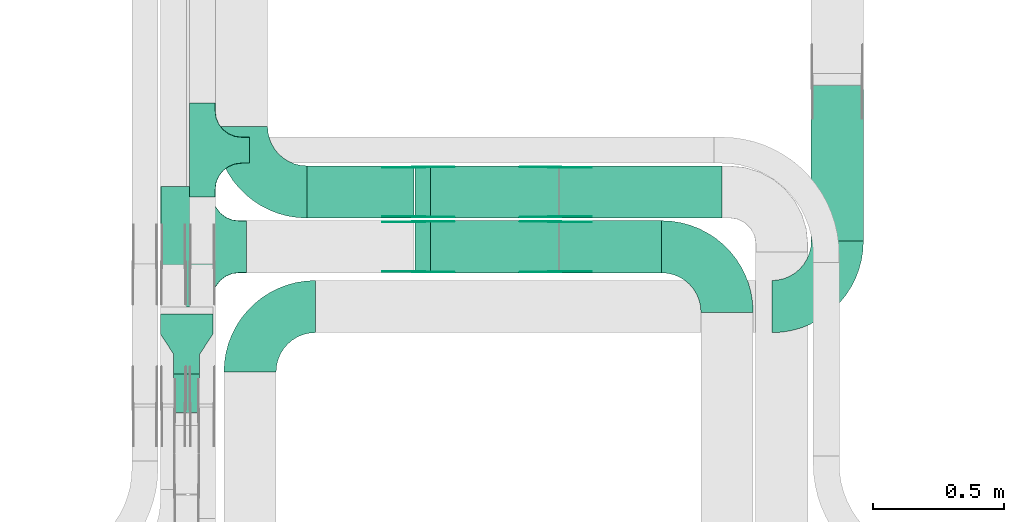
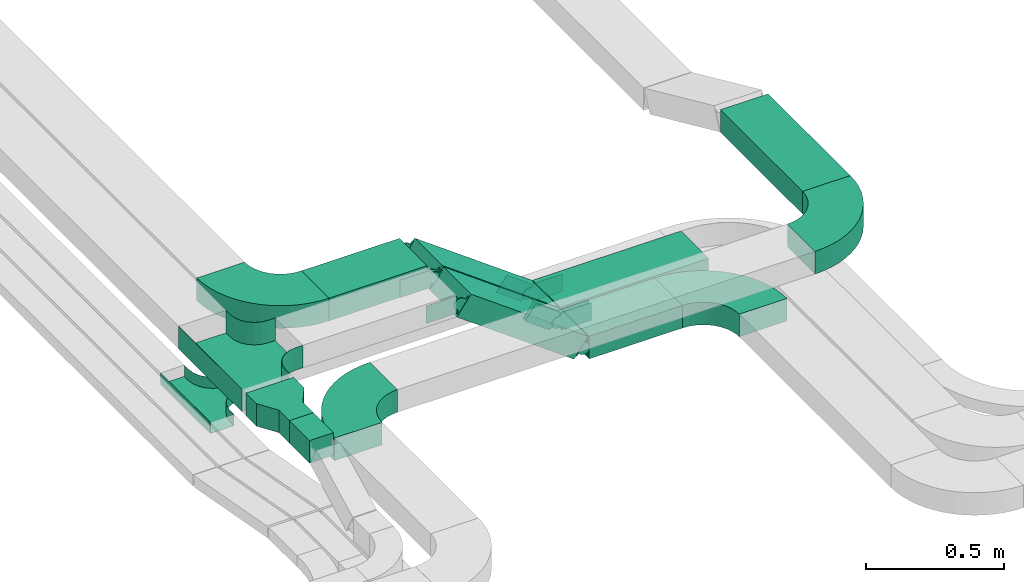
# One storey, part 11 of 25: 23 flow fittings, 7 flow segments.
"""IFC2X3 building model written with IfcOpenShell, lengths in millimetres."""

from ifc_helpers import new_model, entity, si_unit, converted_unit, derived_unit, direction, frame, frame_2d, origin, origin_2d_with_axis, place, context, subcontext, project, spatial, polyline, circle_curve, parameter, trimmed, segment, composite_curve, rectangle, outline, extrude, faceted_brep, source, transform, mapped, material, type_object, type_shapes, element, save


model = new_model("IFC2X3")

# Units and contexts
model_context = context("Model", 3, precision=0.01, world=origin(), true_north=direction((6.12303176911189e-17, 1.0)))
body_context = subcontext(model_context, "Body", "Model", "MODEL_VIEW")
ifc_project = project(units=[si_unit("LENGTHUNIT", "METRE", prefix="MILLI"), si_unit("AREAUNIT", "SQUARE_METRE"), si_unit("VOLUMEUNIT", "CUBIC_METRE"), converted_unit("PLANEANGLEUNIT", "DEGREE", entity("IfcRatioMeasure", 0.0174532925199433), si_unit("PLANEANGLEUNIT", "RADIAN"), dimensions=[0, 0, 0, 0, 0, 0, 0]), si_unit("MASSUNIT", "GRAM", prefix="KILO"), derived_unit("MASSDENSITYUNIT", [(si_unit("MASSUNIT", "GRAM", prefix="KILO"), 1), (si_unit("LENGTHUNIT", "METRE"), -3)]), derived_unit("MOMENTOFINERTIAUNIT", [(si_unit("LENGTHUNIT", "METRE"), 4)]), si_unit("TIMEUNIT", "SECOND"), si_unit("FREQUENCYUNIT", "HERTZ"), si_unit("THERMODYNAMICTEMPERATUREUNIT", "DEGREE_CELSIUS"), derived_unit("THERMALTRANSMITTANCEUNIT", [(si_unit("MASSUNIT", "GRAM", prefix="KILO"), 1), (si_unit("THERMODYNAMICTEMPERATUREUNIT", "KELVIN"), -1), (si_unit("TIMEUNIT", "SECOND"), -3)]), derived_unit("VOLUMETRICFLOWRATEUNIT", [(si_unit("LENGTHUNIT", "METRE"), 3), (si_unit("TIMEUNIT", "SECOND"), -1)]), derived_unit("MASSFLOWRATEUNIT", [(si_unit("MASSUNIT", "GRAM", prefix="KILO"), 1), (si_unit("TIMEUNIT", "SECOND"), -1)]), derived_unit("ROTATIONALFREQUENCYUNIT", [(si_unit("TIMEUNIT", "SECOND"), -1)]), si_unit("ELECTRICCURRENTUNIT", "AMPERE"), si_unit("ELECTRICVOLTAGEUNIT", "VOLT"), si_unit("POWERUNIT", "WATT"), si_unit("FORCEUNIT", "NEWTON", prefix="KILO"), si_unit("ILLUMINANCEUNIT", "LUX"), si_unit("LUMINOUSFLUXUNIT", "LUMEN"), si_unit("LUMINOUSINTENSITYUNIT", "CANDELA"), derived_unit("USERDEFINED", [(si_unit("MASSUNIT", "GRAM", prefix="KILO"), -1), (si_unit("LENGTHUNIT", "METRE"), -2), (si_unit("TIMEUNIT", "SECOND"), 3), (si_unit("LUMINOUSFLUXUNIT", "LUMEN"), 1)]), derived_unit("LINEARVELOCITYUNIT", [(si_unit("LENGTHUNIT", "METRE"), 1), (si_unit("TIMEUNIT", "SECOND"), -1)]), si_unit("PRESSUREUNIT", "PASCAL"), derived_unit("USERDEFINED", [(si_unit("LENGTHUNIT", "METRE"), -2), (si_unit("MASSUNIT", "GRAM", prefix="KILO"), 1), (si_unit("TIMEUNIT", "SECOND"), -2)]), derived_unit("LINEARFORCEUNIT", [(si_unit("MASSUNIT", "GRAM", prefix="KILO"), 1), (si_unit("LENGTHUNIT", "METRE"), 1), (si_unit("TIMEUNIT", "SECOND"), -2), (si_unit("LENGTHUNIT", "METRE"), -1)]), derived_unit("PLANARFORCEUNIT", [(si_unit("MASSUNIT", "GRAM", prefix="KILO"), 1), (si_unit("LENGTHUNIT", "METRE"), 1), (si_unit("TIMEUNIT", "SECOND"), -2), (si_unit("LENGTHUNIT", "METRE"), -2)])], contexts=[model_context])

# Site, building, storey
site_placement = place(None, frame((0.0, -0.00077364408347762, 0.0)))
site = spatial("IfcSite", under=ifc_project, at=site_placement, CompositionType="ELEMENT")
building_placement = place(site_placement, origin())
building = spatial("IfcBuilding", under=site, at=building_placement, CompositionType="ELEMENT")
storey_placement = place(building_placement, frame((0.0, 0.0, 24000.0)))
storey = spatial("IfcBuildingStorey", under=building, at=storey_placement, CompositionType="ELEMENT", Elevation=24000.0)

# Flow segments
cable_carrier_segment_type = type_object("IfcCableCarrierSegmentType", PredefinedType="CABLETRAYSEGMENT")
flow_segment_1_placement = place(storey_placement, frame((32993.0827924389, 10042.896434791, 3040.0)))
element("IfcFlowSegment", 1, at=flow_segment_1_placement, inside=storey, type_object=cable_carrier_segment_type, context=body_context, shape_type="SweptSolid", body=[
    extrude(rectangle(XDim=145.816041854674, YDim=100.000000000003, at=frame_2d((-1.08713038571295e-12, 2.16715534406831e-12), x_axis=(1.0, 0.0))), frame((50.0, 72.9080209273693, 0.0), z_axis=(0.0, 0.0, 1.0), x_axis=(0.0, -1.0, 0.0)), (0.0, 0.0, 1.0), 100.000000000003),
])
flow_segment_2_placement = place(storey_placement, frame((35435.6156945545, 10698.8235638228, 2890.0)))
element("IfcFlowSegment", 2, at=flow_segment_2_placement, inside=storey, type_object=cable_carrier_segment_type, context=body_context, shape_type="SweptSolid", body=[
    extrude(rectangle(XDim=596.343306129946, YDim=199.999999999998, at=origin_2d_with_axis()), frame((100.0, 298.171653064974, 0.0), z_axis=(0.0, 0.0, 1.0), x_axis=(0.0, 1.0, 0.0)), (0.0, 0.0, 1.0), 100.000000000003),
])
flow_segment_3_placement = place(storey_placement, frame((34471.7109059291, 10576.9003960975, 2660.0)))
element("IfcFlowSegment", 3, at=flow_segment_3_placement, inside=storey, type_object=cable_carrier_segment_type, context=body_context, shape_type="SweptSolid", body=[
    extrude(rectangle(XDim=390.371886509737, YDim=199.999999999998, at=frame_2d((-2.1600499167107e-12, -1.08002495835535e-12), x_axis=(1.0, 0.0))), frame((195.185943254866, 100.0, 0.0)), (0.0, 0.0, 1.0), 99.9999999999989),
])
flow_segment_4_placement = place(storey_placement, frame((33504.0827924389, 10786.9003960974, 3040.0)))
element("IfcFlowSegment", 4, at=flow_segment_4_placement, inside=storey, type_object=cable_carrier_segment_type, context=body_context, shape_type="SweptSolid", body=[
    extrude(rectangle(XDim=410.371886509728, YDim=200.000000000002, at=origin_2d_with_axis()), frame((205.185943254864, 100.0, 0.0)), (0.0, 0.0, 1.0), 100.000000000003),
])
flow_segment_5_placement = place(storey_placement, frame((34471.7109059291, 10786.9003960974, 2660.0)))
element("IfcFlowSegment", 5, at=flow_segment_5_placement, inside=storey, type_object=cable_carrier_segment_type, context=body_context, shape_type="SweptSolid", body=[
    extrude(rectangle(XDim=621.371886509741, YDim=200.000000000002, at=frame_2d((4.32009983342141e-12, 0.0), x_axis=(1.0, 0.0))), frame((310.685943254875, 100.0, 0.0)), (0.0, 0.0, 1.0), 100.000000000008),
])
flow_segment_6_placement = place(storey_placement, frame((33918.6221364282, 10576.9003960975, 2680.62133987453)))
element("IfcFlowSegment", 6, at=flow_segment_6_placement, inside=storey, type_object=cable_carrier_segment_type, context=body_context, shape_type="SweptSolid", body=[
    extrude(rectangle(XDim=100.000000000002, YDim=199.999999999998, at=origin_2d_with_axis()), frame((29.5008294671183, 100.0, 398.3877641381), z_axis=(0.807391122257865, 0.0, -0.590016589342356), x_axis=(0.590016589342356, 0.0, 0.807391122257865)), (0.0, 0.0, 1.0), 606.79346054361),
])
flow_segment_7_placement = place(storey_placement, frame((33918.6221364282, 10786.9003960974, 2680.62133987453)))
element("IfcFlowSegment", 7, at=flow_segment_7_placement, inside=storey, type_object=cable_carrier_segment_type, context=body_context, shape_type="SweptSolid", body=[
    extrude(rectangle(XDim=100.000000000002, YDim=200.000000000002, at=origin_2d_with_axis()), frame((29.5008294671139, 100.0, 398.387764138074), z_axis=(0.807391122257865, 0.0, -0.590016589342356), x_axis=(0.590016589342356, 0.0, 0.807391122257865)), (0.0, 0.0, 1.0), 606.793460543608),
])

# Flow fittings
ifc_material_1 = material(Name="G")
cable_carrier_fitting_type_1 = type_object("IfcCableCarrierFittingType", PredefinedType="NOTDEFINED", material=ifc_material_1)
shared_shape_1 = source(origin(), body_context, "Body", "SweptSolid", [
    extrude(outline(composite_curve([segment(trimmed(circle_curve(frame_2d((-41.4651162790697, 0.0), x_axis=(1.0, 0.0)), 25.0), [parameter(90.0000000000007)], [parameter(270.0)], True, "PARAMETER"), True, "CONTINUOUS"), segment(polyline([(-41.4651162790697, -25.0), (-29.9651162790697, -25.0)]), True, "CONTINUOUS"), segment(polyline([(-29.9651162790697, -25.0), (-28.1046511627907, -38.5)]), True, "CONTINUOUS"), segment(polyline([(-28.1046511627907, -38.5), (99.5348837209303, -38.5)]), True, "CONTINUOUS"), segment(polyline([(99.5348837209303, -38.5), (99.5348837209303, 38.5)]), True, "CONTINUOUS"), segment(polyline([(99.5348837209303, 38.5), (-28.1046511627907, 38.5)]), True, "CONTINUOUS"), segment(polyline([(-28.1046511627907, 38.5), (-29.9651162790697, 25.0)]), True, "CONTINUOUS"), segment(polyline([(-29.9651162790697, 25.0), (-41.46511627907, 25.0)]), True, "CONTINUOUS")], self_intersect=False)), frame((41.4651162790697, 0.0, 0.0), z_axis=(0.0, 0.0, -1.0), x_axis=(1.0, 0.0, 0.0)), (0.0, 0.0, -1.0), 2.0),
])
type_shapes(cable_carrier_fitting_type_1, [shared_shape_1])
for number, where, z_axis, x_axis in (
    (8, (34453.0827924389, 10772.3603961076, 2710.0), (0.0, 1.0, 0.0), (-0.807391122257826, 0.0, 0.590016589342409)),
    (9, (33933.0827924389, 10772.3603961076, 3090.0), (0.0, 1.0, 0.0), (0.807391122257826, 0.0, -0.590016589342409)),
    (10, (34453.0827924389, 10982.3603961076, 2710.0), (0.0, 1.0, 0.0), (-0.807391122257826, 0.0, 0.590016589342409)),
    (11, (33933.0827924389, 10982.3603961076, 3090.0), (0.0, 1.0, 0.0), (0.807391122257826, 0.0, -0.590016589342409)),
):
    element("IfcFlowFitting", number, at=place(storey_placement, frame(where, z_axis=z_axis, x_axis=x_axis)), inside=storey, type_object=cable_carrier_fitting_type_1, material=ifc_material_1, context=body_context, shape_type="MappedRepresentation", body=[
        mapped(shared_shape_1, transform((0.0, 0.0, 0.0), scale=1.0)),
    ])
cable_carrier_fitting_type_2 = type_object("IfcCableCarrierFittingType", PredefinedType="NOTDEFINED", material=ifc_material_1)
shared_shape_2 = source(origin(), body_context, "Body", "SweptSolid", [
    extrude(outline(composite_curve([segment(trimmed(circle_curve(frame_2d((-41.4651162790697, 0.0), x_axis=(1.0, 0.0)), 25.0), [parameter(90.0000000000007)], [parameter(270.0)], True, "PARAMETER"), True, "CONTINUOUS"), segment(polyline([(-41.4651162790697, -25.0), (-29.9651162790697, -25.0)]), True, "CONTINUOUS"), segment(polyline([(-29.9651162790697, -25.0), (-28.1046511627907, -38.5)]), True, "CONTINUOUS"), segment(polyline([(-28.1046511627907, -38.5), (99.5348837209303, -38.5)]), True, "CONTINUOUS"), segment(polyline([(99.5348837209303, -38.5), (99.5348837209303, 38.5)]), True, "CONTINUOUS"), segment(polyline([(99.5348837209303, 38.5), (-28.1046511627907, 38.5)]), True, "CONTINUOUS"), segment(polyline([(-28.1046511627907, 38.5), (-29.9651162790697, 25.0)]), True, "CONTINUOUS"), segment(polyline([(-29.9651162790697, 25.0), (-41.46511627907, 25.0)]), True, "CONTINUOUS")], self_intersect=False)), frame((41.4651162790697, 0.0, 0.0)), (0.0, 0.0, 1.0), 2.0),
])
type_shapes(cable_carrier_fitting_type_2, [shared_shape_2])
for number, where, z_axis, x_axis in (
    (12, (34453.0827924389, 10581.4403960873, 2710.0), (0.0, -1.0, 0.0), (-0.807391122257826, 0.0, 0.590016589342409)),
    (13, (33933.0827924389, 10581.4403960873, 3090.0), (0.0, -1.0, 0.0), (0.807391122257826, 0.0, -0.590016589342409)),
    (14, (34453.0827924389, 10791.4403960873, 2710.0), (0.0, -1.0, 0.0), (-0.807391122257826, 0.0, 0.590016589342409)),
    (15, (33933.0827924389, 10791.4403960873, 3090.0), (0.0, -1.0, 0.0), (0.807391122257826, 0.0, -0.590016589342409)),
):
    element("IfcFlowFitting", number, at=place(storey_placement, frame(where, z_axis=z_axis, x_axis=x_axis)), inside=storey, type_object=cable_carrier_fitting_type_2, material=ifc_material_1, context=body_context, shape_type="MappedRepresentation", body=[
        mapped(shared_shape_2, transform((0.0, 0.0, 0.0), scale=1.0)),
    ])
cable_carrier_fitting_type_3 = type_object("IfcCableCarrierFittingType", PredefinedType="NOTDEFINED", material=ifc_material_1)
shared_shape_3 = source(origin(), body_context, "Body", "SweptSolid", [
    extrude(outline(composite_curve([segment(trimmed(circle_curve(frame_2d((-41.4651162790697, 0.0), x_axis=(1.0, 0.0)), 25.0), [parameter(90.0000000000007)], [parameter(270.0)], True, "PARAMETER"), True, "CONTINUOUS"), segment(polyline([(-41.4651162790697, -25.0), (-29.9651162790697, -25.0)]), True, "CONTINUOUS"), segment(polyline([(-29.9651162790697, -25.0), (-28.1046511627907, -38.5)]), True, "CONTINUOUS"), segment(polyline([(-28.1046511627907, -38.5), (99.5348837209303, -38.5)]), True, "CONTINUOUS"), segment(polyline([(99.5348837209303, -38.5), (99.5348837209303, 38.5)]), True, "CONTINUOUS"), segment(polyline([(99.5348837209303, 38.5), (-28.1046511627907, 38.5)]), True, "CONTINUOUS"), segment(polyline([(-28.1046511627907, 38.5), (-29.9651162790697, 25.0)]), True, "CONTINUOUS"), segment(polyline([(-29.9651162790697, 25.0), (-41.46511627907, 25.0)]), True, "CONTINUOUS")], self_intersect=False)), frame((41.4651162790697, 0.0, 0.0), z_axis=(0.0, 0.0, -1.0), x_axis=(1.0, 0.0, 0.0)), (0.0, 0.0, -1.0), 2.0),
])
type_shapes(cable_carrier_fitting_type_3, [shared_shape_3])
for number, where, z_axis, x_axis in (
    (16, (34453.0827924389, 10583.4403960873, 2710.0), (0.0, -1.0, 0.0), (1.0, 0.0, 0.0)),
    (17, (33933.0827924389, 10583.4403960873, 3090.0), (0.0, -1.0, 0.0), (-1.0, 0.0, 0.0)),
    (18, (34453.0827924389, 10793.4403960873, 2710.0), (0.0, -1.0, 0.0), (1.0, 0.0, 0.0)),
    (19, (33933.0827924389, 10793.4403960873, 3090.0), (0.0, -1.0, 0.0), (-1.0, 0.0, 0.0)),
):
    element("IfcFlowFitting", number, at=place(storey_placement, frame(where, z_axis=z_axis, x_axis=x_axis)), inside=storey, type_object=cable_carrier_fitting_type_3, material=ifc_material_1, context=body_context, shape_type="MappedRepresentation", body=[
        mapped(shared_shape_3, transform((0.0, 0.0, 0.0), scale=1.0)),
    ])
cable_carrier_fitting_type_4 = type_object("IfcCableCarrierFittingType", PredefinedType="NOTDEFINED", material=ifc_material_1)
shared_shape_4 = source(origin(), body_context, "Body", "SweptSolid", [
    extrude(outline(composite_curve([segment(trimmed(circle_curve(frame_2d((-41.4651162790697, 0.0), x_axis=(1.0, 0.0)), 25.0), [parameter(90.0000000000007)], [parameter(270.0)], True, "PARAMETER"), True, "CONTINUOUS"), segment(polyline([(-41.4651162790697, -25.0), (-29.9651162790697, -25.0)]), True, "CONTINUOUS"), segment(polyline([(-29.9651162790697, -25.0), (-28.1046511627907, -38.5)]), True, "CONTINUOUS"), segment(polyline([(-28.1046511627907, -38.5), (99.5348837209303, -38.5)]), True, "CONTINUOUS"), segment(polyline([(99.5348837209303, -38.5), (99.5348837209303, 38.5)]), True, "CONTINUOUS"), segment(polyline([(99.5348837209303, 38.5), (-28.1046511627907, 38.5)]), True, "CONTINUOUS"), segment(polyline([(-28.1046511627907, 38.5), (-29.9651162790697, 25.0)]), True, "CONTINUOUS"), segment(polyline([(-29.9651162790697, 25.0), (-41.46511627907, 25.0)]), True, "CONTINUOUS")], self_intersect=False)), frame((41.4651162790697, 0.0, 0.0)), (0.0, 0.0, 1.0), 2.0),
])
type_shapes(cable_carrier_fitting_type_4, [shared_shape_4])
for number, where, z_axis, x_axis in (
    (20, (34453.0827924389, 10770.3603961076, 2710.0), (0.0, 1.0, 0.0), (1.0, 0.0, 0.0)),
    (21, (33933.0827924389, 10770.3603961076, 3090.0), (0.0, 1.0, 0.0), (-1.0, 0.0, 0.0)),
    (22, (34453.0827924389, 10980.3603961076, 2710.0), (0.0, 1.0, 0.0), (1.0, 0.0, 0.0)),
    (23, (33933.0827924389, 10980.3603961076, 3090.0), (0.0, 1.0, 0.0), (-1.0, 0.0, 0.0)),
):
    element("IfcFlowFitting", number, at=place(storey_placement, frame(where, z_axis=z_axis, x_axis=x_axis)), inside=storey, type_object=cable_carrier_fitting_type_4, material=ifc_material_1, context=body_context, shape_type="MappedRepresentation", body=[
        mapped(shared_shape_4, transform((0.0, 0.0, 0.0), scale=1.0)),
    ])
ifc_material_2 = material()
cable_carrier_fitting_type_5 = type_object("IfcCableCarrierFittingType", Name="470_DKC_S5_Variable Angle Elbow 0-45:-", PredefinedType="NOTDEFINED", material=ifc_material_2)
shared_shape_5 = source(origin(), body_context, "Body", "SweptSolid", [
    extrude(outline(composite_curve([segment(polyline([(-125.750000000001, -225.25), (-124.749999999999, -225.25)]), True, "CONTINUOUS"), segment(trimmed(circle_curve(frame_2d((-124.75, 124.75), x_axis=(0.0, -1.0)), 350.0), [parameter(0.0)], [parameter(90.0000000000001)], True, "PARAMETER"), True, "CONTINUOUS"), segment(polyline([(225.25, 124.75), (225.25, 125.749999999999)]), True, "CONTINUOUS"), segment(polyline([(225.25, 125.749999999999), (25.25, 125.750000000001)]), True, "CONTINUOUS"), segment(polyline([(25.25, 125.750000000001), (25.25, 124.75)]), True, "CONTINUOUS"), segment(trimmed(circle_curve(frame_2d((-124.75, 124.75), x_axis=(0.0, -1.0)), 150.0), [parameter(0.0)], [parameter(90.0000000000001)], True, "PARAMETER"), False, "CONTINUOUS"), segment(polyline([(-124.749999999999, -25.2500000000003), (-125.750000000001, -25.2500000000003)]), True, "CONTINUOUS"), segment(polyline([(-125.750000000001, -25.2500000000003), (-125.750000000001, -225.25)]), True, "CONTINUOUS")], self_intersect=False)), frame((-125.249999999991, 125.249999999992, -50.0)), (0.0, 0.0, 1.0), 100.0),
])
type_shapes(cable_carrier_fitting_type_5, [shared_shape_5])
flow_fitting_1_placement = place(storey_placement, frame((33285.8855251231, 10447.8235638228, 2940.0), z_axis=(0.0, 0.0, 1.0), x_axis=(-1.0, 0.0, 0.0)))
element("IfcFlowFitting", 24, at=flow_fitting_1_placement, inside=storey, type_object=cable_carrier_fitting_type_5, material=ifc_material_2, Name="470_DKC_S5_Variable Angle Elbow 0-45:-", ObjectType="470_DKC_S5_Variable Angle Elbow 0-45:-", context=body_context, shape_type="MappedRepresentation", body=[
    mapped(shared_shape_5, transform((0.0, 0.0, 0.0), scale=1.0)),
])
flow_fitting_2_placement = place(storey_placement, frame((35535.6156945545, 10447.8235638228, 2940.0)))
element("IfcFlowFitting", 25, at=flow_fitting_2_placement, inside=storey, type_object=cable_carrier_fitting_type_5, material=ifc_material_2, Name="470_DKC_S5_Variable Angle Elbow 0-45:-", ObjectType="470_DKC_S5_Variable Angle Elbow 0-45:-", context=body_context, shape_type="MappedRepresentation", body=[
    mapped(shared_shape_5, transform((0.0, 0.0, 0.0), scale=1.0)),
])
for number, where, z_axis, x_axis, name in (
    (26, (35113.0827924389, 10676.9003960975, 2710.0), (0.0, 0.0, 1.0), (0.0, 1.0, 0.0), "470_DKC_S5_Variable Angle Elbow 0-45:-"),
    (27, (33253.0827924389, 10886.9003960974, 3090.0), (0.0, 0.0, 1.0), (0.0, -1.0, 0.0), "470_DKC_S5_Variable Angle Elbow 0-45:-"),
):
    element("IfcFlowFitting", number, at=place(storey_placement, frame(where, z_axis=z_axis, x_axis=x_axis)), inside=storey, type_object=cable_carrier_fitting_type_5, material=ifc_material_2, Name=name, ObjectType="470_DKC_S5_Variable Angle Elbow 0-45:-", context=body_context, shape_type="MappedRepresentation", body=[
        mapped(shared_shape_5, transform((0.0, 0.0, 0.0), scale=1.0)),
    ])
cable_carrier_fitting_type_6 = type_object("IfcCableCarrierFittingType", PredefinedType="NOTDEFINED", material=ifc_material_2)
shared_shape_6 = source(origin(), body_context, "Body", "Brep", [
    faceted_brep([(-103.407417371087, -174.118095489753, 50.0), (-100.0, -200.0, 50.0), (-100.0, -230.0, 50.0), (-99.1999999999932, -230.0, 50.0), (-99.1999999999933, -200.0, 50.0), (-102.634676710055, -173.911040253671, 50.0), (-112.704639298522, -149.600000000004, 50.0), (-128.723636456391, -128.7236364564, 50.0), (-149.599999999996, -112.704639298532, 50.0), (-173.911040253663, -102.634676710066, 50.0), (-200.0, -99.2000000000044, 50.0), (-230.0, -99.2000000000044, 50.0), (-230.0, -100.0, 50.0), (-200.0, -100.0, 50.0), (-174.118095489746, -103.407417371099, 50.0), (-150.0, -113.397459621561, 50.0), (-129.28932188134, -129.28932188135, 50.0), (-113.39745962155, -150.0, 50.0), (230.0, -100.0, 50.0), (230.0, -99.2000000000044, 50.0), (200.0, -99.2000000000097, 50.0), (173.911040253722, -102.634676710071, 50.0), (149.60000000005, -112.704639298537, 50.0), (128.723636456439, -128.723636456403, 50.0), (112.704639298563, -149.600000000006, 50.0), (102.634676710086, -173.911040253673, 50.0), (99.2000000000121, -200.0, 50.0), (99.2000000000069, -230.0, 50.0), (100.0, -230.0, 50.0), (100.0, -200.0, 50.0), (103.407417371119, -174.118095489755, 50.0), (113.397459621593, -150.0, 50.0), (129.289321881391, -129.289321881354, 50.0), (150.0, -113.397459621567, 50.0), (174.118095489805, -103.407417371105, 50.0), (200.0, -100.0, 50.0), (230.0, 99.1999999999954, 50.0), (230.0, 100.0, 50.0), (-230.0, 100.0, 50.0), (-230.0, 99.1999999999954, 50.0), (-230.0, -100.0, -50.0), (-230.0, 100.0, -50.0), (230.0, 100.0, -50.0), (230.0, -100.0, -50.0), (200.0, -100.0, -50.0), (174.118095489805, -103.407417371105, -50.0), (150.0, -113.397459621567, -50.0), (129.289321881391, -129.289321881354, -50.0), (113.397459621593, -150.0, -50.0), (103.407417371119, -174.118095489755, -50.0), (100.0, -200.0, -50.0), (100.0, -230.0, -50.0), (-100.0, -230.0, -50.0), (-100.0, -200.0, -50.0), (-103.407417371087, -174.118095489753, -50.0), (-113.39745962155, -150.0, -50.0), (-129.28932188134, -129.28932188135, -50.0), (-150.0, -113.397459621561, -50.0), (-174.118095489746, -103.407417371099, -50.0), (-200.0, -100.0, -50.0), (-100.0, -200.0, -49.1999999999851), (99.2000000000069, -230.0, -49.1999999999851), (-99.1999999999932, -230.0, -49.1999999999851), (-99.1999999999933, -200.0, -49.1999999999851), (-200.0, -99.2000000000044, -49.1999999999851), (-230.0, -99.2000000000044, -49.1999999999851), (230.0, -99.2000000000044, -49.1999999999851), (200.0, -99.2000000000044, -49.1999999999851), (-230.0, 99.1999999999954, -49.1999999999851), (-200.0, -100.0, -49.1999999999851), (200.0, -100.0, -49.1999999999851), (230.0, 99.1999999999954, -49.1999999999851), (99.2000000000121, -200.0, -49.1999999999851), (100.0, -200.0, -49.1999999999851), (-173.911040253663, -102.634676710066, -49.1999999999851), (-149.599999999996, -112.704639298532, -49.1999999999851), (-128.723636456391, -128.7236364564, -49.1999999999851), (-112.704639298522, -149.600000000004, -49.1999999999851), (-102.634676710055, -173.911040253671, -49.1999999999851), (102.634676710086, -173.911040253674, -49.1999999999851), (112.704639298563, -149.600000000007, -49.1999999999851), (128.723636456439, -128.723636456403, -49.1999999999851), (149.60000000005, -112.704639298537, -49.1999999999851), (173.911040253721, -102.634676710071, -49.1999999999851)], [[[0, 1, 2, 3, 4, 5, 6, 7, 8, 9, 10, 11, 12, 13, 14, 15, 16, 17]], [[18, 19, 20, 21, 22, 23, 24, 25, 26, 27, 28, 29, 30, 31, 32, 33, 34, 35]], [[36, 37, 38, 39]], [[40, 41, 42, 43, 44, 45, 46, 47, 48, 49, 50, 51, 52, 53, 54, 55, 56, 57, 58, 59]], [[2, 1, 60, 53, 52]], [[3, 2, 52, 51, 28, 27, 61, 62]], [[4, 3, 62, 63]], [[11, 10, 64, 65]], [[20, 19, 66, 67]], [[39, 38, 41, 40, 12, 11, 65, 68]], [[13, 12, 40, 59, 69]], [[18, 35, 70, 44, 43]], [[19, 18, 43, 42, 37, 36, 71, 66]], [[27, 26, 72, 61]], [[29, 28, 51, 50, 73]], [[38, 37, 42, 41]], [[36, 39, 68, 71]], [[68, 65, 64, 74, 75, 76, 77, 78, 63, 62, 61, 72, 79, 80, 81, 82, 83, 67, 66, 71]], [[14, 13, 69, 59, 58]], [[15, 14, 58, 57]], [[57, 56, 16, 15]], [[17, 16, 56, 55]], [[0, 17, 55, 54]], [[1, 0, 54, 53, 60]], [[5, 78, 77, 6]], [[6, 77, 76, 7]], [[63, 78, 5, 4]], [[8, 75, 74, 9]], [[9, 74, 64, 10]], [[7, 76, 75, 8]], [[21, 83, 82, 22]], [[22, 82, 81, 23]], [[67, 83, 21, 20]], [[24, 80, 79, 25]], [[25, 79, 72, 26]], [[23, 81, 80, 24]], [[30, 29, 73, 50, 49]], [[31, 30, 49, 48]], [[32, 31, 48, 47]], [[34, 33, 46, 45]], [[34, 45, 44, 70, 35]], [[46, 33, 32, 47]]]),
])
type_shapes(cable_carrier_fitting_type_6, [shared_shape_6])
flow_fitting_3_placement = place(storey_placement, frame((33043.0827924389, 10676.9003960973, 3090.0), z_axis=(0.0, 0.0, 1.0), x_axis=(0.0, 1.0, 0.0)))
element("IfcFlowFitting", 28, at=flow_fitting_3_placement, inside=storey, type_object=cable_carrier_fitting_type_6, material=ifc_material_2, Name="470_DKC_S5_T", context=body_context, shape_type="MappedRepresentation", body=[
    mapped(shared_shape_6, transform((0.0, 0.0, 0.0), scale=1.0)),
])
cable_carrier_fitting_type_7 = type_object("IfcCableCarrierFittingType", PredefinedType="NOTDEFINED", material=ifc_material_2)
shared_shape_7 = source(origin(), body_context, "Body", "SweptSolid", [
    extrude(outline(polyline([(-115.0, -100.0), (-38.3333333333284, -100.0), (38.3333333333252, -50.0), (115.0, -50.0), (115.0, 50.0), (38.3333333333382, 50.0), (-38.3333333333284, 100.0), (-115.0, 100.0), (-115.0, -100.0)])), frame((115.0, 0.0, -50.0)), (0.0, 0.0, 1.0), 100.0),
])
type_shapes(cable_carrier_fitting_type_7, [shared_shape_7])
flow_fitting_4_placement = place(storey_placement, frame((33043.0827924389, 10418.7124766457, 3090.0), z_axis=(0.0, 0.0, 1.0), x_axis=(0.0, -1.0, 0.0)))
element("IfcFlowFitting", 29, at=flow_fitting_4_placement, inside=storey, type_object=cable_carrier_fitting_type_7, material=ifc_material_2, Name="470_DKC_S5_adapter", context=body_context, shape_type="MappedRepresentation", body=[
    mapped(shared_shape_7, transform((0.0, 0.0, 0.0), scale=1.0)),
])
cable_carrier_fitting_type_8 = type_object("IfcCableCarrierFittingType", PredefinedType="NOTDEFINED", material=ifc_material_2)
shared_shape_8 = source(origin(), body_context, "Body", "Brep", [
    faceted_brep([(-53.4074173710859, -124.118095489752, 25.0), (-50.0, -150.0, 25.0), (-50.0, -180.0, 25.0), (-49.1999999999934, -180.0, 25.0), (-49.1999999999926, -150.0, 25.0), (-52.6346767100545, -123.91104025367, 25.0), (-62.7046392985216, -99.6000000000037, 25.0), (-78.7236364563899, -78.7236364563991, 25.0), (-99.5999999999949, -62.7046392985315, 25.0), (-123.911040253662, -52.6346767100651, 25.0), (-150.0, -49.2000000000047, 25.0), (-180.0, -49.2000000000047, 25.0), (-180.0, -50.0, 25.0), (-150.0, -50.0, 25.0), (-124.118095489745, -53.4074173710983, 25.0), (-100.0, -63.3974596215602, 25.0), (-79.2893218813398, -79.2893218813488, 25.0), (-63.3974596215496, -100.0, 25.0), (180.0, -50.0, 25.0), (180.0, -49.2000000000047, 25.0), (150.0, -49.2000000000046, 25.0), (123.911040253717, -52.634676710066, 25.0), (99.6000000000452, -62.7046392985316, 25.0), (78.7236364564342, -78.7236364563979, 25.0), (62.7046392985581, -99.6000000000012, 25.0), (52.6346767100809, -123.911040253668, 25.0), (49.200000000007, -150.0, 25.0), (49.2000000000071, -180.0, 25.0), (50.0, -180.0, 25.0), (50.0, -150.0, 25.0), (53.4074173711136, -124.11809548975, 25.0), (63.3974596215874, -100.0, 25.0), (79.2893218813853, -79.2893218813486, 25.0), (100.0, -63.3974596215613, 25.0), (124.1180954898, -53.4074173710999, 25.0), (150.0, -50.0, 25.0), (180.0, 49.1999999999958, 25.0), (180.0, 50.0, 25.0), (-180.0, 50.0, 25.0), (-180.0, 49.1999999999958, 25.0), (-180.0, -50.0, -25.0), (-180.0, 50.0, -25.0), (180.0, 50.0, -25.0), (180.0, -50.0, -25.0), (150.0, -50.0, -25.0), (124.1180954898, -53.4074173710999, -25.0), (100.0, -63.3974596215613, -25.0), (79.2893218813853, -79.2893218813486, -25.0), (63.3974596215874, -100.0, -25.0), (53.4074173711136, -124.11809548975, -25.0), (50.0, -150.0, -25.0), (50.0, -180.0, -25.0), (-50.0, -180.0, -25.0), (-50.0, -150.0, -25.0), (-53.4074173710859, -124.118095489752, -25.0), (-63.3974596215496, -100.0, -25.0), (-79.2893218813398, -79.2893218813488, -25.0), (-100.0, -63.3974596215602, -25.0), (-124.118095489745, -53.4074173710983, -25.0), (-150.0, -50.0, -25.0), (-50.0, -150.0, -24.199999999986), (49.2000000000071, -180.0, -24.199999999986), (-49.1999999999934, -180.0, -24.199999999986), (-49.1999999999926, -150.0, -24.199999999986), (-150.0, -49.2000000000047, -24.199999999986), (-180.0, -49.2000000000047, -24.199999999986), (180.0, -49.2000000000047, -24.199999999986), (150.0, -49.2000000000047, -24.199999999986), (-180.0, 49.1999999999958, -24.199999999986), (-150.0, -50.0, -24.199999999986), (150.0, -50.0, -24.199999999986), (180.0, 49.1999999999958, -24.199999999986), (49.200000000007, -150.0, -24.199999999986), (50.0, -150.0, -24.199999999986), (-123.911040253662, -52.6346767100651, -24.199999999986), (-99.5999999999949, -62.7046392985315, -24.199999999986), (-78.7236364563899, -78.7236364563991, -24.199999999986), (-62.7046392985217, -99.6000000000036, -24.199999999986), (-52.6346767100546, -123.91104025367, -24.199999999986), (52.6346767100807, -123.911040253669, -24.199999999986), (62.7046392985577, -99.6000000000018, -24.199999999986), (78.7236364564338, -78.7236364563983, -24.199999999986), (99.6000000000446, -62.704639298532, -24.199999999986), (123.911040253716, -52.6346767100662, -24.199999999986)], [[[0, 1, 2, 3, 4, 5, 6, 7, 8, 9, 10, 11, 12, 13, 14, 15, 16, 17]], [[18, 19, 20, 21, 22, 23, 24, 25, 26, 27, 28, 29, 30, 31, 32, 33, 34, 35]], [[36, 37, 38, 39]], [[40, 41, 42, 43, 44, 45, 46, 47, 48, 49, 50, 51, 52, 53, 54, 55, 56, 57, 58, 59]], [[2, 1, 60, 53, 52]], [[3, 2, 52, 51, 28, 27, 61, 62]], [[4, 3, 62, 63]], [[11, 10, 64, 65]], [[20, 19, 66, 67]], [[39, 38, 41, 40, 12, 11, 65, 68]], [[13, 12, 40, 59, 69]], [[18, 35, 70, 44, 43]], [[19, 18, 43, 42, 37, 36, 71, 66]], [[27, 26, 72, 61]], [[29, 28, 51, 50, 73]], [[38, 37, 42, 41]], [[36, 39, 68, 71]], [[68, 65, 64, 74, 75, 76, 77, 78, 63, 62, 61, 72, 79, 80, 81, 82, 83, 67, 66, 71]], [[14, 13, 69, 59, 58]], [[58, 57, 15, 14]], [[15, 57, 56, 16]], [[0, 17, 55, 54]], [[0, 54, 53, 60, 1]], [[55, 17, 16, 56]], [[5, 4, 63, 78]], [[6, 5, 78, 77]], [[7, 6, 77, 76]], [[8, 7, 76, 75]], [[9, 8, 75, 74]], [[10, 9, 74, 64]], [[21, 20, 67, 83]], [[22, 21, 83, 82]], [[23, 22, 82, 81]], [[81, 80, 24, 23]], [[24, 80, 79, 25]], [[79, 72, 26, 25]], [[30, 29, 73, 50, 49]], [[31, 30, 49, 48]], [[31, 48, 47, 32]], [[33, 32, 47, 46]], [[45, 34, 33, 46]], [[34, 45, 44, 70, 35]]]),
])
type_shapes(cable_carrier_fitting_type_8, [shared_shape_8])
flow_fitting_5_placement = place(storey_placement, frame((33103.0827924389, 11046.900396097, 2675.04095576845), z_axis=(0.0, 0.0, 1.0), x_axis=(0.0, 1.0, 0.0)))
element("IfcFlowFitting", 30, at=flow_fitting_5_placement, inside=storey, type_object=cable_carrier_fitting_type_8, material=ifc_material_2, Name="470_DKC_S5_T", context=body_context, shape_type="MappedRepresentation", body=[
    mapped(shared_shape_8, transform((0.0, 0.0, 0.0), scale=1.0)),
])

save(model, "model.ifc")
